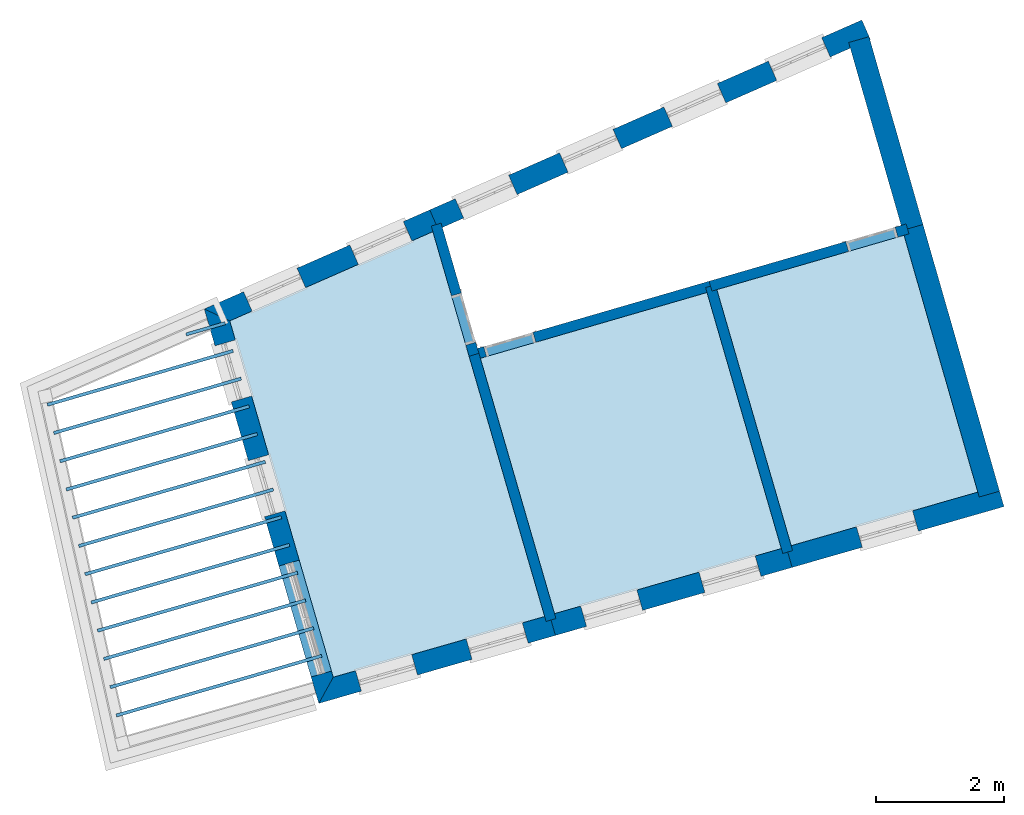
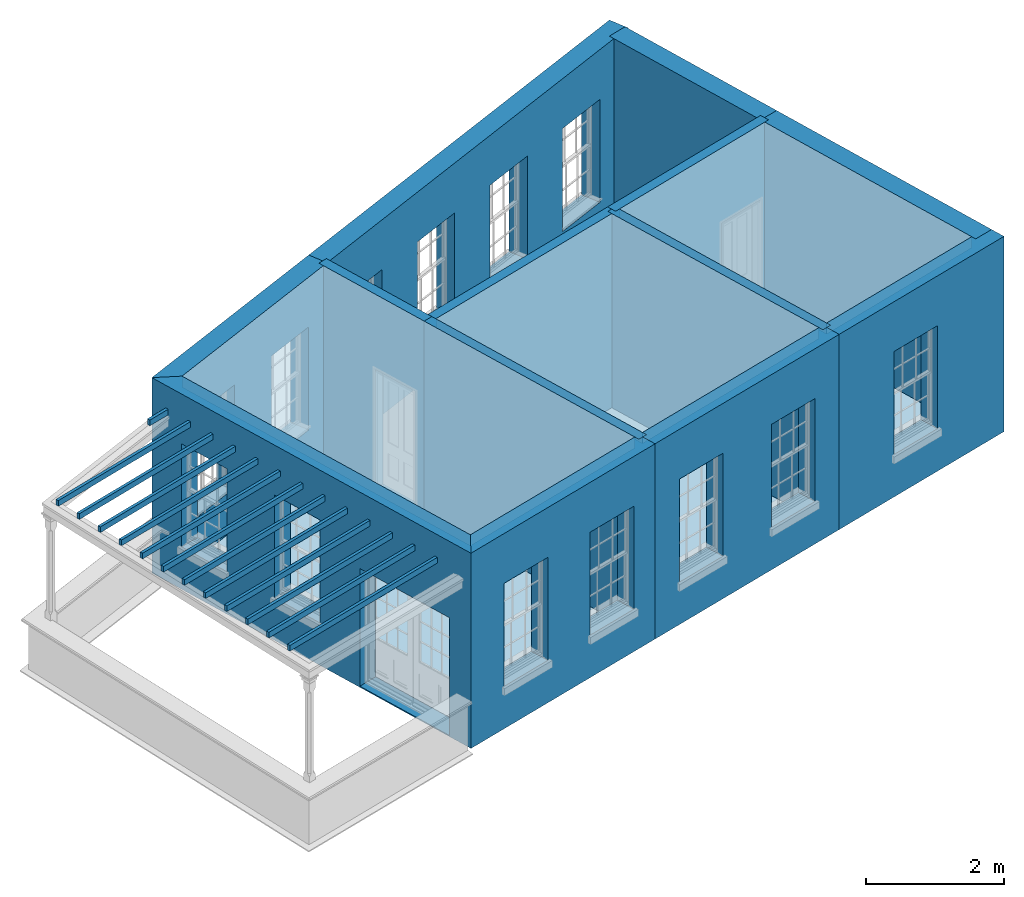
# One storey, part 1 of 11: 19 slabs, 13 walls, 17 openings.
"""IFC2X3 building model written with IfcOpenShell, lengths in metres."""

from ifc_helpers import new_model, si_unit, frame, origin, place, context, subcontext, project, spatial, polyline, outline, extrude, material, layer, layer_set, layer_usage, element, save


model = new_model("IFC2X3")

# Units and contexts
model_context = context("Model", 3, world=origin())
body_context = subcontext(model_context, "Body", "Model", "MODEL_VIEW")
ifc_project = project(units=[si_unit("PLANEANGLEUNIT", "RADIAN"), si_unit("MASSUNIT", "GRAM", prefix="KILO"), si_unit("FORCEUNIT", "NEWTON", prefix="KILO"), si_unit("LENGTHUNIT", "METRE")], contexts=[model_context])

# Site, building, storey
site_placement = place(None, origin())
site = spatial("IfcSite", under=ifc_project, at=site_placement, CompositionType="ELEMENT")
building_placement = place(None, origin())
building = spatial("IfcBuilding", under=site, at=building_placement, Name="Building plot-15", CompositionType="ELEMENT")
storey_placement = place(None, frame((0.0, 0.0, 7.6)))
storey = spatial("IfcBuildingStorey", under=building, at=storey_placement, Name="Floor 1", CompositionType="ELEMENT", Elevation=7.6)

# Slabs
slab_1_placement = place(storey_placement, frame((0.0, 0.0, 2.95)))
element("IfcSlab", 1, at=slab_1_placement, inside=storey, Name="Slab", ObjectType="Slab", PredefinedType="FLOOR", context=body_context, shape_type="SweptSolid", body=[
    extrude(outline(polyline([(87.1271876995855, 50.7778965535459), (87.1132441369049, 50.8259129784417), (83.9124454842043, 49.896428187794), (83.9263890468849, 49.8484117628982), (87.1271876995855, 50.7778965535459)])), origin(), (0.0, 0.0, 1.0), 0.1),
])
slab_2_placement = place(storey_placement, frame((0.0, 0.0, 2.95)))
element("IfcSlab", 2, at=slab_2_placement, inside=storey, Name="Slab", ObjectType="Slab", PredefinedType="FLOOR", context=body_context, shape_type="SweptSolid", body=[
    extrude(outline(polyline([(87.0016956354601, 51.210044377608), (86.9877520727795, 51.2580608025037), (83.8148171153028, 50.3366673927056), (83.8287606779834, 50.2886509678098), (87.0016956354601, 51.210044377608)])), origin(), (0.0, 0.0, 1.0), 0.1),
])
slab_3_placement = place(storey_placement, frame((0.0, 0.0, 2.95)))
element("IfcSlab", 3, at=slab_3_placement, inside=storey, Name="Slab", ObjectType="Slab", PredefinedType="FLOOR", context=body_context, shape_type="SweptSolid", body=[
    extrude(outline(polyline([(86.8762035713347, 51.64219220167), (86.8622600086541, 51.6902086265658), (83.7171887464012, 50.7769065976172), (83.7311323090818, 50.7288901727214), (86.8762035713347, 51.64219220167)])), origin(), (0.0, 0.0, 1.0), 0.1),
])
slab_4_placement = place(storey_placement, frame((0.0, 0.0, 2.95)))
element("IfcSlab", 4, at=slab_4_placement, inside=storey, Name="Slab", ObjectType="Slab", PredefinedType="FLOOR", context=body_context, shape_type="SweptSolid", body=[
    extrude(outline(polyline([(86.7507115072093, 52.074340025732), (86.7367679445287, 52.1223564506278), (83.6195603774997, 51.2171458025288), (83.6335039401803, 51.169129377633), (86.7507115072093, 52.074340025732)])), origin(), (0.0, 0.0, 1.0), 0.1),
])
slab_5_placement = place(storey_placement, frame((0.0, 0.0, 2.95)))
element("IfcSlab", 5, at=slab_5_placement, inside=storey, Name="Slab", ObjectType="Slab", PredefinedType="FLOOR", context=body_context, shape_type="SweptSolid", body=[
    extrude(outline(polyline([(86.6252194430839, 52.5064878497941), (86.6112758804033, 52.5545042746898), (83.5219320085981, 51.6573850074404), (83.5358755712787, 51.6093685825446), (86.6252194430839, 52.5064878497941)])), origin(), (0.0, 0.0, 1.0), 0.1),
])
slab_6_placement = place(storey_placement, frame((0.0, 0.0, 2.95)))
element("IfcSlab", 6, at=slab_6_placement, inside=storey, Name="Slab", ObjectType="Slab", PredefinedType="FLOOR", context=body_context, shape_type="SweptSolid", body=[
    extrude(outline(polyline([(86.4997273789585, 52.9386356738561), (86.4857838162779, 52.9866520987519), (83.4243036396966, 52.097624212352), (83.4382472023772, 52.0496077874562), (86.4997273789585, 52.9386356738561)])), origin(), (0.0, 0.0, 1.0), 0.1),
])
slab_7_placement = place(storey_placement, frame((0.0, 0.0, 2.95)))
element("IfcSlab", 7, at=slab_7_placement, inside=storey, Name="Slab", ObjectType="Slab", PredefinedType="FLOOR", context=body_context, shape_type="SweptSolid", body=[
    extrude(outline(polyline([(86.3742353148331, 53.3707834979181), (86.3602917521525, 53.4187999228139), (83.326675270795, 52.5378634172636), (83.3406188334756, 52.4898469923678), (86.3742353148331, 53.3707834979181)])), origin(), (0.0, 0.0, 1.0), 0.1),
])
slab_8_placement = place(storey_placement, frame((0.0, 0.0, 2.95)))
element("IfcSlab", 8, at=slab_8_placement, inside=storey, Name="Slab", ObjectType="Slab", PredefinedType="FLOOR", context=body_context, shape_type="SweptSolid", body=[
    extrude(outline(polyline([(86.2487432507077, 53.8029313219802), (86.2347996880271, 53.8509477468759), (83.2290469018935, 52.9781026221752), (83.2429904645741, 52.9300861972794), (86.2487432507077, 53.8029313219802)])), origin(), (0.0, 0.0, 1.0), 0.1),
])
slab_9_placement = place(storey_placement, frame((0.0, 0.0, 2.95)))
element("IfcSlab", 9, at=slab_9_placement, inside=storey, Name="Slab", ObjectType="Slab", PredefinedType="FLOOR", context=body_context, shape_type="SweptSolid", body=[
    extrude(outline(polyline([(86.1232511865823, 54.2350791460422), (86.1093076239017, 54.283095570938), (83.1314185329919, 53.4183418270868), (83.1453620956725, 53.370325402191), (86.1232511865823, 54.2350791460422)])), origin(), (0.0, 0.0, 1.0), 0.1),
])
slab_10_placement = place(storey_placement, frame((0.0, 0.0, 2.95)))
element("IfcSlab", 10, at=slab_10_placement, inside=storey, Name="Slab", ObjectType="Slab", PredefinedType="FLOOR", context=body_context, shape_type="SweptSolid", body=[
    extrude(outline(polyline([(85.9977591224569, 54.6672269701042), (85.9838155597763, 54.715243395), (83.0337901640904, 53.8585810319984), (83.047733726771, 53.8105646071026), (85.9977591224569, 54.6672269701042)])), origin(), (0.0, 0.0, 1.0), 0.1),
])
slab_11_placement = place(storey_placement, frame((0.0, 0.0, 2.95)))
element("IfcSlab", 11, at=slab_11_placement, inside=storey, Name="Slab", ObjectType="Slab", PredefinedType="FLOOR", context=body_context, shape_type="SweptSolid", body=[
    extrude(outline(polyline([(85.8722670583316, 55.0993747941662), (85.858323495651, 55.147391219062), (82.9361617951888, 54.29882023691), (82.9501053578694, 54.2508038120142), (85.8722670583316, 55.0993747941662)])), origin(), (0.0, 0.0, 1.0), 0.1),
])
slab_12_placement = place(storey_placement, frame((0.0, 0.0, 2.95)))
element("IfcSlab", 12, at=slab_12_placement, inside=storey, Name="Slab", ObjectType="Slab", PredefinedType="FLOOR", context=body_context, shape_type="SweptSolid", body=[
    extrude(outline(polyline([(85.7467749942062, 55.5315226182283), (85.7328314315256, 55.5795390431241), (82.8385334262873, 54.7390594418216), (82.8524769889679, 54.6910430169259), (85.7467749942062, 55.5315226182283)])), origin(), (0.0, 0.0, 1.0), 0.1),
])
slab_13_placement = place(storey_placement, frame((0.0, 0.0, 2.95)))
element("IfcSlab", 13, at=slab_13_placement, inside=storey, Name="Slab", ObjectType="Slab", PredefinedType="FLOOR", context=body_context, shape_type="SweptSolid", body=[
    extrude(outline(polyline([(85.6212829300808, 55.9636704422903), (85.6073393674002, 56.0116868671861), (85.0004776470143, 55.8354593688868), (85.0144212096948, 55.787442943991), (85.6212829300808, 55.9636704422903)])), origin(), (0.0, 0.0, 1.0), 0.1),
])
slab_14_placement = place(storey_placement, frame((0.0, 0.0, 3.25)))
element("IfcSlab", 14, at=slab_14_placement, inside=storey, Name="Slab", ObjectType="Slab", PredefinedType="FLOOR", context=body_context, shape_type="SweptSolid", body=[
    extrude(outline(polyline([(93.1259419481481, 56.4653028026416), (89.5934562606152, 55.4394989093001), (90.7492750995838, 51.4592902821545), (94.2845837491432, 52.4747060086671), (93.1259419481481, 56.4653028026416)])), origin(), (0.0, 0.0, 1.0), 0.2),
])
slab_15_placement = place(storey_placement, frame((0.0, 0.0, 3.25)))
element("IfcSlab", 15, at=slab_15_placement, inside=storey, Name="Slab", ObjectType="Slab", PredefinedType="FLOOR", context=body_context, shape_type="SweptSolid", body=[
    extrude(outline(polyline([(96.1971993792139, 57.357169920847), (93.2795945079686, 56.5099222032643), (94.4383668549021, 52.5188757826638), (97.3469163931548, 53.3542729813922), (96.1971993792139, 57.357169920847)])), origin(), (0.0, 0.0, 1.0), 0.2),
])
slab_16_placement = place(storey_placement, frame((0.0, 0.0, 3.25)))
element("IfcSlab", 16, at=slab_16_placement, inside=storey, Name="Slab", ObjectType="Slab", PredefinedType="FLOOR", context=body_context, shape_type="SweptSolid", body=[
    extrude(outline(polyline([(87.3002897494389, 50.4686684405552), (90.5954919738373, 51.415120502417), (88.8534242925765, 57.4141513022723), (85.6873979783644, 56.0228656256528), (87.3002897494389, 50.4686684405552)])), origin(), (0.0, 0.0, 1.0), 0.2),
])
slab_17_placement = place(storey_placement, origin())
element("IfcSlab", 17, at=slab_17_placement, inside=storey, Name="Slab", ObjectType="Slab", PredefinedType="FLOOR", context=body_context, shape_type="SweptSolid", body=[
    extrude(outline(polyline([(93.1259419481481, 56.4653028026416), (89.5934562606152, 55.4394989093001), (90.7492750995838, 51.4592902821545), (94.2845837491432, 52.4747060086671), (93.1259419481481, 56.4653028026416)])), origin(), (0.0, 0.0, 1.0), 0.02),
])
slab_18_placement = place(storey_placement, origin())
element("IfcSlab", 18, at=slab_18_placement, inside=storey, Name="Slab", ObjectType="Slab", PredefinedType="FLOOR", context=body_context, shape_type="SweptSolid", body=[
    extrude(outline(polyline([(96.1971993792139, 57.357169920847), (93.2795945079686, 56.5099222032643), (94.4383668549021, 52.5188757826638), (97.3469163931548, 53.3542729813922), (96.1971993792139, 57.357169920847)])), origin(), (0.0, 0.0, 1.0), 0.02),
])
slab_19_placement = place(storey_placement, origin())
element("IfcSlab", 19, at=slab_19_placement, inside=storey, Name="Slab", ObjectType="Slab", PredefinedType="FLOOR", context=body_context, shape_type="SweptSolid", body=[
    extrude(outline(polyline([(87.3002897494389, 50.4686684405552), (90.5954919738373, 51.415120502417), (88.8534242925765, 57.4141513022723), (85.6873979783644, 56.0228656256528), (87.3002897494389, 50.4686684405552)])), origin(), (0.0, 0.0, 1.0), 0.02),
])

# Wall, openings
ifc_material_1 = material(Name="Masonry")
ifc_layer_1 = layer(ifc_material_1, 0.33, ventilated=False)
ifc_layer_set_1 = layer_set([ifc_layer_1], Name="My Wall")
ifc_layer_usage_1 = layer_usage(ifc_layer_set_1, "AXIS2", "NEGATIVE", 0.08)
wall_1_placement = place(storey_placement, origin())
wall_1 = element("IfcWallStandardCase", 20, at=wall_1_placement, inside=storey, material=ifc_layer_usage_1, Name="exterior", context=body_context, shape_type="SweptSolid", body=[
    extrude(outline(polyline([(95.6723187451732, 60.4106615143609), (95.5395561949644, 60.7127775603797), (88.804220166514, 57.7529864488727), (88.9369827167228, 57.4508704028539), (95.6723187451732, 60.4106615143609)])), origin(), (0.0, 0.0, 1.0), 3.45),
])
opening_1_placement = place(storey_placement, frame((0.0, 0.0, 0.75)))
element("IfcOpeningElement", 21, at=opening_1_placement, cuts=wall_1, Name="Opening", ObjectType="Opening", context=body_context, shape_type="SweptSolid", body=[
    extrude(outline(polyline([(94.9139268152625, 60.4378495880681), (94.0808189307863, 60.0717467980984), (94.2135814809951, 59.7696307520796), (95.0466893654713, 60.1357335420493), (94.9139268152625, 60.4378495880681)])), origin(), (0.0, 0.0, 1.0), 1.82),
])
opening_2_placement = place(storey_placement, frame((0.0, 0.0, 0.75)))
element("IfcOpeningElement", 22, at=opening_2_placement, cuts=wall_1, Name="Opening", ObjectType="Opening", context=body_context, shape_type="SweptSolid", body=[
    extrude(outline(polyline([(93.2873117562595, 59.7230462325794), (92.4542038717833, 59.3569434426097), (92.5869664219921, 59.0548273965908), (93.4200743064683, 59.4209301865605), (93.2873117562595, 59.7230462325794)])), origin(), (0.0, 0.0, 1.0), 1.82),
])
opening_3_placement = place(storey_placement, frame((0.0, 0.0, 0.75)))
element("IfcOpeningElement", 23, at=opening_3_placement, cuts=wall_1, Name="Opening", ObjectType="Opening", context=body_context, shape_type="SweptSolid", body=[
    extrude(outline(polyline([(91.6606966972566, 59.0082428770907), (90.8275888127803, 58.642140087121), (90.9603513629891, 58.3400240411021), (91.7934592474653, 58.7061268310718), (91.6606966972566, 59.0082428770907)])), origin(), (0.0, 0.0, 1.0), 1.82),
])
opening_4_placement = place(storey_placement, frame((0.0, 0.0, 0.75)))
element("IfcOpeningElement", 24, at=opening_4_placement, cuts=wall_1, Name="Opening", ObjectType="Opening", context=body_context, shape_type="SweptSolid", body=[
    extrude(outline(polyline([(90.0340816382536, 58.2934395216019), (89.2009737537774, 57.9273367316322), (89.3337363039862, 57.6252206856134), (90.1668441884623, 57.9913234755831), (90.0340816382536, 58.2934395216019)])), origin(), (0.0, 0.0, 1.0), 1.82),
])

wall_2_placement = place(storey_placement, origin())
wall_2 = element("IfcWallStandardCase", 25, at=wall_2_placement, inside=storey, material=ifc_layer_usage_1, Name="exterior", context=body_context, shape_type="SweptSolid", body=[
    extrude(outline(polyline([(88.9369827167228, 57.4508704028539), (88.804220166514, 57.7529864488727), (85.2898260322487, 56.2086132391335), (85.6873979783644, 56.0228656256528), (88.9369827167228, 57.4508704028539)])), origin(), (0.0, 0.0, 1.0), 3.45),
])
opening_5_placement = place(storey_placement, frame((0.0, 0.0, 0.75)))
element("IfcOpeningElement", 26, at=opening_5_placement, cuts=wall_2, Name="Opening", ObjectType="Opening", context=body_context, shape_type="SweptSolid", body=[
    extrude(outline(polyline([(88.3923288698651, 57.5719840172823), (87.5592209853889, 57.2058812273126), (87.6919835355977, 56.9037651812937), (88.5250914200739, 57.2698679712634), (88.3923288698651, 57.5719840172823)])), origin(), (0.0, 0.0, 1.0), 1.82),
])
opening_6_placement = place(storey_placement, frame((0.0, 0.0, 0.75)))
element("IfcOpeningElement", 27, at=opening_6_placement, cuts=wall_2, Name="Opening", ObjectType="Opening", context=body_context, shape_type="SweptSolid", body=[
    extrude(outline(polyline([(86.7354383920912, 56.8438763641317), (85.902330507615, 56.477773574162), (86.0350930578237, 56.1756575281431), (86.8682009422999, 56.5417603181128), (86.7354383920912, 56.8438763641317)])), origin(), (0.0, 0.0, 1.0), 1.82),
])

wall_3_placement = place(storey_placement, origin())
wall_3 = element("IfcWallStandardCase", 28, at=wall_3_placement, inside=storey, material=ifc_layer_usage_1, Name="exterior", context=body_context, shape_type="SweptSolid", body=[
    extrude(outline(polyline([(85.6873979783644, 56.0228656256528), (85.2898260322487, 56.2086132391335), (87.0751399602823, 50.0606585087336), (87.3002897494389, 50.4686684405552), (85.6873979783644, 56.0228656256528)])), origin(), (0.0, 0.0, 1.0), 3.45),
])
opening_7_placement = place(storey_placement, frame((0.0, 0.0, 0.75)))
element("IfcOpeningElement", 29, at=opening_7_placement, cuts=wall_3, Name="Opening", ObjectType="Opening", context=body_context, shape_type="SweptSolid", body=[
    extrude(outline(polyline([(85.4569058524119, 55.6332527075221), (85.7106786931988, 54.7593537744188), (86.0275870975109, 54.8513812881108), (85.773814256724, 55.725280221214), (85.4569058524119, 55.6332527075221)])), origin(), (0.0, 0.0, 1.0), 1.82),
])
opening_8_placement = place(storey_placement, frame((0.0, 0.0, 0.75)))
element("IfcOpeningElement", 30, at=opening_8_placement, cuts=wall_3, Name="Opening", ObjectType="Opening", context=body_context, shape_type="SweptSolid", body=[
    extrude(outline(polyline([(85.9765909320635, 53.8436512858375), (86.2303637728504, 52.9697523527342), (86.5472721771625, 53.0617798664262), (86.2934993363756, 53.9356787995294), (85.9765909320635, 53.8436512858375)])), origin(), (0.0, 0.0, 1.0), 1.82),
])
opening_9_placement = place(storey_placement, frame((0.0, 0.0, 0.0199999999999996)))
element("IfcOpeningElement", 31, at=opening_9_placement, cuts=wall_3, Name="Opening", ObjectType="Opening", context=body_context, shape_type="SweptSolid", body=[
    extrude(outline(polyline([(86.45346077574, 52.2014895544017), (86.9554290322415, 50.4728982581536), (87.2723374365537, 50.5649257718456), (86.7703691800521, 52.2935170680937), (86.45346077574, 52.2014895544017)])), origin(), (0.0, 0.0, 1.0), 2.08),
])

wall_4_placement = place(storey_placement, origin())
wall_4 = element("IfcWallStandardCase", 32, at=wall_4_placement, inside=storey, material=ifc_layer_usage_1, Name="exterior", context=body_context, shape_type="SweptSolid", body=[
    extrude(outline(polyline([(87.3002897494389, 50.4686684405552), (87.0751399602823, 50.0606585087336), (90.763708317877, 51.1200936783008), (90.6726085371998, 51.4372700172048), (87.3002897494389, 50.4686684405552)])), origin(), (0.0, 0.0, 1.0), 3.45),
])
opening_10_placement = place(storey_placement, frame((0.0, 0.0, 0.75)))
element("IfcOpeningElement", 33, at=opening_10_placement, cuts=wall_4, Name="Opening", ObjectType="Opening", context=body_context, shape_type="SweptSolid", body=[
    extrude(outline(polyline([(87.7396504137491, 50.2515200237434), (88.6142881967875, 50.5027345704591), (88.5231884161104, 50.8199109093632), (87.6485506330719, 50.5686963626475), (87.7396504137491, 50.2515200237434)])), origin(), (0.0, 0.0, 1.0), 1.82),
])
opening_11_placement = place(storey_placement, frame((0.0, 0.0, 0.75)))
element("IfcOpeningElement", 34, at=opening_11_placement, cuts=wall_4, Name="Opening", ObjectType="Opening", context=body_context, shape_type="SweptSolid", body=[
    extrude(outline(polyline([(89.4641430888215, 50.7468309445431), (90.33878087186, 50.9980454912588), (90.2476810911828, 51.3152218301628), (89.3730433081444, 51.0640072834471), (89.4641430888215, 50.7468309445431)])), origin(), (0.0, 0.0, 1.0), 1.82),
])

wall_5_placement = place(storey_placement, origin())
wall_5 = element("IfcWallStandardCase", 35, at=wall_5_placement, inside=storey, material=ifc_layer_usage_1, Name="exterior", context=body_context, shape_type="SweptSolid", body=[
    extrude(outline(polyline([(90.6726085371998, 51.4372700172048), (90.763708317877, 51.1200936783008), (94.4527966416063, 52.1796781931848), (94.3616968609291, 52.4968545320888), (90.6726085371998, 51.4372700172048)])), origin(), (0.0, 0.0, 1.0), 3.45),
])
opening_12_placement = place(storey_placement, frame((0.0, 0.0, 0.75)))
element("IfcOpeningElement", 36, at=opening_12_placement, cuts=wall_5, Name="Opening", ObjectType="Opening", context=body_context, shape_type="SweptSolid", body=[
    extrude(outline(polyline([(91.2486615072901, 51.2593825336639), (92.1232992903285, 51.5105970803796), (92.0321995096514, 51.8277734192837), (91.1575617266129, 51.5765588725679), (91.2486615072901, 51.2593825336639)])), origin(), (0.0, 0.0, 1.0), 1.82),
])
opening_13_placement = place(storey_placement, frame((0.0, 0.0, 0.75)))
element("IfcOpeningElement", 37, at=opening_13_placement, cuts=wall_5, Name="Opening", ObjectType="Opening", context=body_context, shape_type="SweptSolid", body=[
    extrude(outline(polyline([(93.0932056691547, 51.7891747911059), (93.9678434521932, 52.0403893378216), (93.876743671516, 52.3575656767257), (93.0021058884776, 52.1063511300099), (93.0932056691547, 51.7891747911059)])), origin(), (0.0, 0.0, 1.0), 1.82),
])

# Wall, opening
wall_6_placement = place(storey_placement, origin())
wall_6 = element("IfcWallStandardCase", 38, at=wall_6_placement, inside=storey, material=ifc_layer_usage_1, Name="exterior", context=body_context, shape_type="SweptSolid", body=[
    extrude(outline(polyline([(94.3616968609291, 52.4968545320888), (94.4527966416063, 52.1796781931848), (97.755192512736, 53.1281964231653), (97.6640927320589, 53.4453727620694), (94.3616968609291, 52.4968545320888)])), origin(), (0.0, 0.0, 1.0), 3.45),
])
opening_14_placement = place(storey_placement, frame((0.0, 0.0, 0.75)))
element("IfcOpeningElement", 39, at=opening_14_placement, cuts=wall_6, Name="Opening", ObjectType="Opening", context=body_context, shape_type="SweptSolid", body=[
    extrude(outline(polyline([(95.5465331330367, 52.4938225421364), (96.4211709160752, 52.7450370888522), (96.3300711353981, 53.0622134277562), (95.4554333523596, 52.8109988810405), (95.5465331330367, 52.4938225421364)])), origin(), (0.0, 0.0, 1.0), 1.82),
])

# Walls
wall_7_placement = place(storey_placement, origin())
element("IfcWallStandardCase", 40, at=wall_7_placement, inside=storey, material=ifc_layer_usage_1, Name="party", context=body_context, shape_type="SweptSolid", body=[
    extrude(outline(polyline([(97.3690011884705, 53.2773817477185), (97.6861775273745, 53.3684815283957), (96.4922262033301, 57.5253862648866), (96.1750498644261, 57.4342864842094), (97.3690011884705, 53.2773817477185)])), origin(), (0.0, 0.0, 1.0), 3.45),
])
wall_8_placement = place(storey_placement, origin())
element("IfcWallStandardCase", 41, at=wall_8_placement, inside=storey, material=ifc_layer_usage_1, Name="party", context=body_context, shape_type="SweptSolid", body=[
    extrude(outline(polyline([(96.1750498644261, 57.4342864842094), (96.4922262033301, 57.5253862648866), (95.6515431973083, 60.4523390637506), (95.3343668584043, 60.3612392830734), (96.1750498644261, 57.4342864842094)])), origin(), (0.0, 0.0, 1.0), 3.45),
])

# Wall, opening
ifc_material_2 = material(Name="Masonry")
ifc_layer_2 = layer(ifc_material_2, 0.16, ventilated=False)
ifc_layer_set_2 = layer_set([ifc_layer_2], Name="My Wall")
ifc_layer_usage_2 = layer_usage(ifc_layer_set_2, "AXIS2", "NEGATIVE", 0.08)
wall_9_placement = place(storey_placement, origin())
wall_9 = element("IfcWallStandardCase", 42, at=wall_9_placement, inside=storey, material=ifc_layer_usage_2, Name="interior", context=body_context, shape_type="SweptSolid", body=[
    extrude(outline(polyline([(89.472010580204, 55.5708417686776), (89.516629980782, 55.4171892090111), (93.2027716667049, 56.4876135015068), (93.1581522661269, 56.6412660611732), (89.472010580204, 55.5708417686776)])), origin(), (0.0, 0.0, 1.0), 3.45),
])
opening_15_placement = place(storey_placement, frame((0.0, 0.0, 0.0199999999999996)))
element("IfcOpeningElement", 43, at=opening_15_placement, cuts=wall_9, Name="Opening", ObjectType="Opening", context=body_context, shape_type="SweptSolid", body=[
    extrude(outline(polyline([(89.6894891104068, 55.4673860346613), (90.4577519087393, 55.6904830375509), (90.4131325081614, 55.8441355972174), (89.6448697098289, 55.6210385943278), (89.6894891104068, 55.4673860346613)])), origin(), (0.0, 0.0, 1.0), 2.1),
])

wall_10_placement = place(storey_placement, origin())
wall_10 = element("IfcWallStandardCase", 44, at=wall_10_placement, inside=storey, material=ifc_layer_usage_2, Name="interior", context=body_context, shape_type="SweptSolid", body=[
    extrude(outline(polyline([(88.9816241358994, 57.5464203567232), (88.8279715762328, 57.5018009561452), (89.4174940006597, 55.4717057885554), (89.5711465603263, 55.5163251891334), (88.9816241358994, 57.5464203567232)])), origin(), (0.0, 0.0, 1.0), 3.45),
])
opening_16_placement = place(storey_placement, frame((0.0, 0.0, 0.0199999999999996)))
element("IfcOpeningElement", 45, at=opening_16_placement, cuts=wall_10, Name="Opening", ObjectType="Opening", context=body_context, shape_type="SweptSolid", body=[
    extrude(outline(polyline([(89.14420017212, 56.4128277165127), (89.3672971750096, 55.6445649181802), (89.5209497346761, 55.6891843187582), (89.2978527317865, 56.4574471170907), (89.14420017212, 56.4128277165127)])), origin(), (0.0, 0.0, 1.0), 2.1),
])

# Wall
wall_11_placement = place(storey_placement, origin())
element("IfcWallStandardCase", 46, at=wall_11_placement, inside=storey, material=ifc_layer_usage_2, Name="interior", context=body_context, shape_type="SweptSolid", body=[
    extrude(outline(polyline([(89.5711465603263, 55.5163251891334), (89.4174940006597, 55.4717057885554), (90.6178670526822, 51.3380690832421), (90.7715196123488, 51.3826884838201), (89.5711465603263, 55.5163251891334)])), origin(), (0.0, 0.0, 1.0), 3.45),
])

# Wall, opening
wall_12_placement = place(storey_placement, origin())
wall_12 = element("IfcWallStandardCase", 47, at=wall_12_placement, inside=storey, material=ifc_layer_usage_2, Name="interior", context=body_context, shape_type="SweptSolid", body=[
    extrude(outline(polyline([(93.1581522661269, 56.6412660611732), (93.2027716667049, 56.4876135015068), (96.2742507983888, 57.3795449996919), (96.2296313978108, 57.5331975593583), (93.1581522661269, 56.6412660611732)])), origin(), (0.0, 0.0, 1.0), 3.45),
])
opening_17_placement = place(storey_placement, frame((0.0, 0.0, 0.0199999999999996)))
element("IfcOpeningElement", 48, at=opening_17_placement, cuts=wall_12, Name="Opening", ObjectType="Opening", context=body_context, shape_type="SweptSolid", body=[
    extrude(outline(polyline([(95.3331288704315, 57.1062511711521), (96.101391668764, 57.3293481740417), (96.056772268186, 57.4830007337082), (95.2885094698535, 57.2599037308186), (95.3331288704315, 57.1062511711521)])), origin(), (0.0, 0.0, 1.0), 2.1),
])

# Wall
wall_13_placement = place(storey_placement, origin())
element("IfcWallStandardCase", 49, at=wall_13_placement, inside=storey, material=ifc_layer_usage_2, Name="interior", context=body_context, shape_type="SweptSolid", body=[
    extrude(outline(polyline([(93.257289244726, 56.5867460429601), (93.1036346881058, 56.5421335197199), (94.3069543779347, 52.397657036795), (94.4606089345549, 52.4422695600352), (93.257289244726, 56.5867460429601)])), origin(), (0.0, 0.0, 1.0), 3.45),
])

save(model, "model.ifc")
